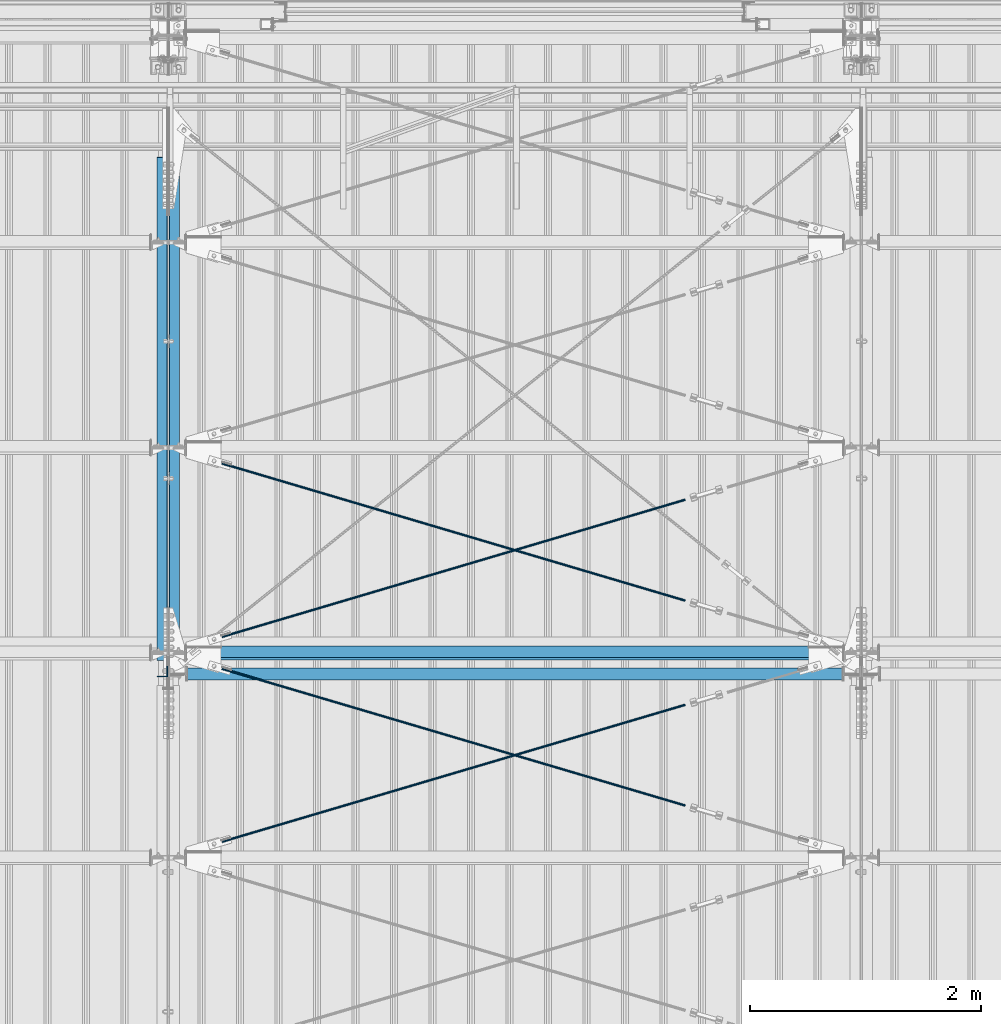
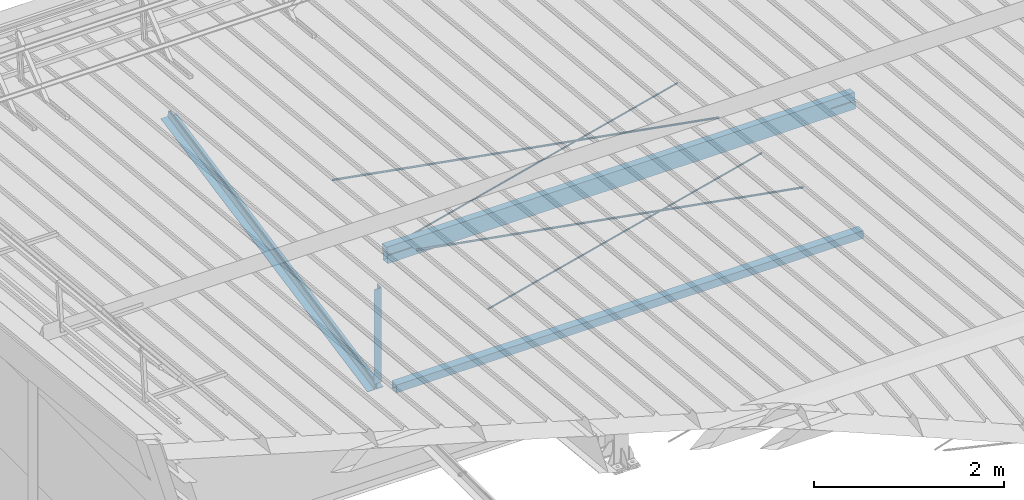
# One storey, part 263 of 709: 9 beams, 6 openings, 9 elements without a shape of their own.
"""IFC4 building model written with IfcOpenShell, lengths in millimetres."""

import ifcopenshell
import ifcopenshell.guid

model = None  # the IFC model being written
_history = None  # IfcOwnerHistory: only IFC2X3 demands one
_inside = {}  # id of a spatial element -> (the spatial element, [elements in it])
_under = {}  # id of a project, library or spatial element -> (it, [spatial elements below it])
_declared = {}  # id of a project -> (the project, [libraries it declares])
_typed = {}  # id of a type object -> (the type object, [elements of that type])
_made_of = {}  # id of a material, layer set ... -> (it, [elements and type objects made of it])


def new_model(schema):
    """Start an empty IFC model of exactly this schema.

    Asked for "IFC4X3", IfcOpenShell would pick the latest addendum, in which some entities
    have other attributes; the version numbers below select the first issue.
    IFC2X3 requires an IfcOwnerHistory on every rooted entity: one is made here for all.
    """
    global model, _history
    if schema == "IFC4X3":
        model = ifcopenshell.file(schema_version=(4, 3, 0, 0))
    else:
        model = ifcopenshell.file(schema=schema)
    _inside.clear()
    _under.clear()
    _declared.clear()
    _typed.clear()
    _made_of.clear()
    _history = None
    if model.schema == "IFC2X3":
        org = make("IfcOrganization", Name="unknown")
        user = make(
            "IfcPersonAndOrganization",
            ThePerson=make("IfcPerson", FamilyName="unknown"),
            TheOrganization=org,
        )
        app = make(
            "IfcApplication",
            ApplicationDeveloper=org,
            Version="unknown",
            ApplicationFullName="unknown",
            ApplicationIdentifier="unknown",
        )
        _history = make(
            "IfcOwnerHistory",
            OwningUser=user,
            OwningApplication=app,
            ChangeAction="ADDED",
            CreationDate=0,
        )
    return model


def make(cls, **values):
    """One entity of the class cls with the attributes given. An attribute that is None is left unset."""
    return model.create_entity(
        cls, **{name: value for name, value in values.items() if value is not None}
    )


def rooted(cls, **values):
    """An entity with a GlobalId (a new one), such as an element, a storey or a relation."""
    return make(cls, GlobalId=ifcopenshell.guid.new(), OwnerHistory=_history, **values)


def si_unit(unit_type, name, prefix=None):
    """IfcSIUnit, for example si_unit("LENGTHUNIT", "METRE", prefix="MILLI")."""
    return make("IfcSIUnit", UnitType=unit_type, Prefix=prefix, Name=name)


def assignment(units):
    """IfcUnitAssignment: the units of a project."""
    return None if units is None else make("IfcUnitAssignment", Units=units)


def point(xyz):
    """IfcCartesianPoint."""
    return None if xyz is None else make("IfcCartesianPoint", Coordinates=xyz)


def direction(xyz):
    """IfcDirection."""
    return None if xyz is None else make("IfcDirection", DirectionRatios=xyz)


def frame(location, z_axis=None, x_axis=None):
    """IfcAxis2Placement3D, a coordinate frame: its origin and axes. An axis left out is left unset."""
    return make(
        "IfcAxis2Placement3D",
        Location=point(location),
        Axis=direction(z_axis),
        RefDirection=direction(x_axis),
    )


def origin_with_axes():
    """The frame at (0, 0, 0) with the z axis (0, 0, 1) and the x axis (1, 0, 0) written out."""
    return frame((0.0, 0.0, 0.0), z_axis=(0.0, 0.0, 1.0), x_axis=(1.0, 0.0, 0.0))


def place(relative_to, where):
    """IfcLocalPlacement: puts the frame where relative to a parent placement (None: the world)."""
    return make(
        "IfcLocalPlacement", PlacementRelTo=relative_to, RelativePlacement=where
    )


def context(
    kind, dimensions, precision=None, world=None, true_north=None, identifier=None
):
    """IfcGeometricRepresentationContext, for example the 3D "Model" context."""
    return make(
        "IfcGeometricRepresentationContext",
        ContextIdentifier=identifier,
        ContextType=kind,
        CoordinateSpaceDimension=dimensions,
        Precision=precision,
        WorldCoordinateSystem=world,
        TrueNorth=true_north,
    )


def subcontext(parent, identifier, kind, view, scale=None):
    """IfcGeometricRepresentationSubContext, for example "Body" below "Model"."""
    return make(
        "IfcGeometricRepresentationSubContext",
        ContextIdentifier=identifier,
        ContextType=kind,
        ParentContext=parent,
        TargetScale=scale,
        TargetView=view,
    )


def project(units=None, contexts=None):
    """IfcProject with its units and contexts."""
    return rooted(
        "IfcProject",
        Name="project",
        RepresentationContexts=contexts,
        UnitsInContext=assignment(units),
    )


def spatial(cls, under=None, at=None, **own):
    """A site, building, storey or space (cls), placed at a placement, below another one or the project."""
    s = rooted(cls, ObjectPlacement=at, **own)
    if under is not None:
        _under.setdefault(under.id(), (under, []))[1].append(s)
    return s


def point_list(points):
    """IfcCartesianPointList2D or 3D."""
    cls = (
        "IfcCartesianPointList2D" if len(points[0]) == 2 else "IfcCartesianPointList3D"
    )
    return make(cls, CoordList=points)


def line(*indices):
    """IfcLineIndex: a straight run through numbered points of an indexed curve."""
    return model.create_entity("IfcLineIndex", indices)


def indexed_curve(points, segments=None, self_intersect=None):
    """IfcIndexedPolyCurve: lines and arcs through numbered points (the first is 1)."""
    return make(
        "IfcIndexedPolyCurve",
        Points=point_list(points),
        Segments=segments,
        SelfIntersect=self_intersect,
    )


def outline(outer, holes=None, kind="AREA"):
    """IfcArbitraryClosedProfileDef: a profile drawn as a closed curve; with holes, ...WithVoids."""
    if holes is None:
        return make("IfcArbitraryClosedProfileDef", ProfileType=kind, OuterCurve=outer)
    return make(
        "IfcArbitraryProfileDefWithVoids",
        ProfileType=kind,
        OuterCurve=outer,
        InnerCurves=holes,
    )


def extrude(swept, where, along, depth):
    """IfcExtrudedAreaSolid: the profile swept, set in the frame where, extruded along a direction by depth."""
    return make(
        "IfcExtrudedAreaSolid",
        SweptArea=swept,
        Position=where,
        ExtrudedDirection=direction(along),
        Depth=depth,
    )


def polygons(points, faces, closed=None, point_numbers=None):
    """IfcPolygonalFaceSet: a face is its outer loop, then its inner loops; points numbered from 1."""
    made = []
    for loops in faces:
        if len(loops) == 1:
            made.append(make("IfcIndexedPolygonalFace", CoordIndex=loops[0]))
        else:
            made.append(
                make(
                    "IfcIndexedPolygonalFaceWithVoids",
                    CoordIndex=loops[0],
                    InnerCoordIndices=loops[1:],
                )
            )
    return make(
        "IfcPolygonalFaceSet",
        Coordinates=point_list(points),
        Closed=closed,
        Faces=made,
        PnIndex=point_numbers,
    )


def shape(context_of_items, identifier, shape_type, items):
    """IfcShapeRepresentation: the items that make up one representation, for example the "Body"."""
    return make(
        "IfcShapeRepresentation",
        ContextOfItems=context_of_items,
        RepresentationIdentifier=identifier,
        RepresentationType=shape_type,
        Items=items,
    )


def material(Name=None, Category=None):
    """IfcMaterial."""
    return make("IfcMaterial", Name=Name, Category=Category)


def made_of(thing, what):
    """Note that an element or type object is made of a material, layer set ...; save() writes the relation."""
    if what is not None:
        _made_of.setdefault(what.id(), (what, []))[1].append(thing)
    return thing


def element(
    cls,
    number,
    at=None,
    inside=None,
    cuts=None,
    type_object=None,
    material=None,
    context=None,
    identifier="Body",
    shape_type=None,
    held_by="IfcProductDefinitionShape",
    body=None,
    shapes=None,
    **own,
):
    """One element of the class cls, such as IfcWall. Its Tag is "e" and its number.

    at: its placement. inside: the storey or other place that contains it. cuts: it is an
    opening in that element (IfcRelVoidsElement). A single representation is given by context,
    identifier, shape_type and body (its items); several are given by shapes. held_by: the class
    of the entity that holds the representations. save() writes the other relations.
    """
    e = rooted(cls, Tag="e%d" % number, ObjectPlacement=at, **own)
    if body is not None:
        shapes = [shape(context, identifier, shape_type, body)]
    if shapes is not None:
        e.Representation = make(held_by, Representations=shapes)
    if inside is not None:
        _inside.setdefault(inside.id(), (inside, []))[1].append(e)
    if cuts is not None:
        rooted(
            "IfcRelVoidsElement", RelatingBuildingElement=cuts, RelatedOpeningElement=e
        )
    if type_object is not None:
        _typed.setdefault(type_object.id(), (type_object, []))[1].append(e)
    return made_of(e, material)


def aggregate(whole, parts):
    """IfcRelAggregates: a whole, such as a stair, and the parts it consists of."""
    return rooted("IfcRelAggregates", RelatingObject=whole, RelatedObjects=parts)


def save(model, path):
    """Write the relations noted so far, then the file.

    IfcRelAggregates (storeys below a building ...), IfcRelContainedInSpatialStructure (elements
    in a storey), IfcRelDefinesByType, IfcRelAssociatesMaterial and IfcRelDeclares: one each for
    every whole, place, type object, material and project.
    """
    for whole, parts in _under.values():
        aggregate(whole, parts)
    for where, things in _inside.values():
        rooted(
            "IfcRelContainedInSpatialStructure",
            RelatedElements=things,
            RelatingStructure=where,
        )
    for kind, things in _typed.values():
        rooted("IfcRelDefinesByType", RelatedObjects=things, RelatingType=kind)
    for what, things in _made_of.values():
        rooted("IfcRelAssociatesMaterial", RelatedObjects=things, RelatingMaterial=what)
    for by, libraries in _declared.values():
        rooted("IfcRelDeclares", RelatingContext=by, RelatedDefinitions=libraries)
    model.write(path)


model = new_model("IFC4")

# Units and contexts
model_context = context("Model", 3, precision=0.2, world=origin_with_axes(), true_north=direction((0.0, 1.0)))
body_context = subcontext(model_context, "Body", "Model", "MODEL_VIEW")
reference_context = subcontext(model_context, "Reference", "Model", "MODEL_VIEW")
ifc_project = project(units=[si_unit("LENGTHUNIT", "METRE", prefix="MILLI"), si_unit("AREAUNIT", "SQUARE_METRE"), si_unit("VOLUMEUNIT", "CUBIC_METRE"), si_unit("MASSUNIT", "GRAM", prefix="KILO"), si_unit("TIMEUNIT", "SECOND"), si_unit("PLANEANGLEUNIT", "RADIAN"), si_unit("SOLIDANGLEUNIT", "STERADIAN"), si_unit("THERMODYNAMICTEMPERATUREUNIT", "DEGREE_CELSIUS"), si_unit("LUMINOUSINTENSITYUNIT", "LUMEN")], contexts=[model_context])

# Site, building, storey
site_placement = place(None, origin_with_axes())
site = spatial("IfcSite", under=ifc_project, at=site_placement, CompositionType="ELEMENT")
building_placement = place(site_placement, origin_with_axes())
building = spatial("IfcBuilding", under=site, at=building_placement, Name="Undefined", CompositionType="ELEMENT")
storey_placement = place(building_placement, origin_with_axes())
storey = spatial("IfcBuildingStorey", under=building, at=storey_placement, Name="Undefined", CompositionType="ELEMENT", Elevation=0.0)

# Assembly, beam
assembly_1_placement = place(storey_placement, frame((4051.0, 21649.9404, 7109.99804), z_axis=(0.0, -0.1961161349, 0.9805806757), x_axis=(0.0, -0.9805806757, -0.1961161349)))
assembly_1 = element("IfcElementAssembly", 1, at=assembly_1_placement, inside=storey)
ifc_material_1 = material(Name="C345-5", Category="STEEL")
beam_1_placement = place(assembly_1_placement, origin_with_axes())
beam_1 = element("IfcBeam", 2, at=beam_1_placement, material=ifc_material_1, ObjectType="435", context=body_context, shape_type="Tessellation", body=[
    polygons([(873.96605, -45.0, -45.0), (873.96605, 45.0, -45.0), (5317.375, 45.0, -45.0), (5317.375, -45.0, -45.0), (873.96605, 45.0, -39.0), (5317.375, 45.0, -39.0), (873.96605, -39.0, -39.0), (5317.375, -39.0, -39.0), (873.96605, -39.0, 45.0), (5317.375, -39.0, 45.0), (873.96605, -45.0, 45.0), (5317.375, -45.0, 45.0)], [[[1, 2, 3, 4]], [[2, 5, 6, 3]], [[5, 7, 8, 6]], [[7, 9, 10, 8]], [[9, 11, 12, 10]], [[11, 1, 4, 12]], [[6, 8, 10, 12, 4, 3]], [[11, 9, 7, 5, 2, 1]]], closed=True),
])
aggregate(assembly_1, [beam_1])

assembly_2_placement = place(storey_placement, frame((3949.0, 16322.9404, 6044.59804), z_axis=(0.0, -0.1961161349, 0.9805806757), x_axis=(0.0, 0.9805806757, 0.1961161349)))
assembly_2 = element("IfcElementAssembly", 3, at=assembly_2_placement, inside=storey)
beam_2_placement = place(assembly_2_placement, origin_with_axes())
beam_2 = element("IfcBeam", 4, at=beam_2_placement, material=ifc_material_1, ObjectType="435", context=body_context, shape_type="Tessellation", body=[
    polygons([(115.12039, -45.0, -45.0), (115.12039, 45.0, -45.0), (4558.52934, 45.0, -45.0), (4558.52934, -45.0, -45.0), (115.12039, 45.0, -39.0), (4558.52934, 45.0, -39.0), (115.12039, -39.0, -39.0), (4558.52934, -39.0, -39.0), (115.12039, -39.0, 45.0), (4558.52934, -39.0, 45.0), (115.12039, -45.0, 45.0), (4558.52934, -45.0, 45.0)], [[[1, 2, 3, 4]], [[2, 5, 6, 3]], [[5, 7, 8, 6]], [[7, 9, 10, 8]], [[9, 11, 12, 10]], [[11, 1, 4, 12]], [[6, 8, 10, 12, 4, 3]], [[11, 9, 7, 5, 2, 1]]], closed=True),
])
aggregate(assembly_2, [beam_2])

assembly_3_placement = place(storey_placement, frame((3949.0, 16347.7, 7622.40002), z_axis=(0.0, 1.0, 0.0), x_axis=(0.0, 0.0, -1.0)))
assembly_3 = element("IfcElementAssembly", 5, at=assembly_3_placement, inside=storey)
beam_3_placement = place(assembly_3_placement, origin_with_axes())
beam_3 = element("IfcBeam", 6, at=beam_3_placement, material=ifc_material_1, ObjectType="436", context=body_context, shape_type="Tessellation", body=[
    polygons([(198.6891, -45.0, -45.0), (198.6891, 45.0, -45.0), (1412.4, 45.0, -45.0), (1412.4, -45.0, -45.0), (198.6891, 45.0, -39.0), (1412.4, 45.0, -39.0), (198.6891, -39.0, -39.0), (1412.4, -39.0, -39.0), (198.6891, -39.0, 45.0), (1412.4, -39.0, 45.0), (198.6891, -45.0, 45.0), (1412.4, -45.0, 45.0)], [[[1, 2, 3, 4]], [[2, 5, 6, 3]], [[5, 7, 8, 6]], [[7, 9, 10, 8]], [[9, 11, 12, 10]], [[11, 1, 4, 12]], [[6, 8, 10, 12, 4, 3]], [[11, 9, 7, 5, 2, 1]]], closed=True),
])
aggregate(assembly_3, [beam_3])

assembly_4_placement = place(storey_placement, frame((4000.0, 16327.0, 6074.30002), z_axis=(0.0, -1.0, 0.0), x_axis=(1.0, 0.0, 0.0)))
assembly_4 = element("IfcElementAssembly", 7, at=assembly_4_placement, inside=storey)
ifc_material_2 = material(Name="C355", Category="STEEL")
beam_4_placement = place(assembly_4_placement, origin_with_axes())
beam_4 = element("IfcBeam", 8, at=beam_4_placement, material=ifc_material_2, ObjectType="557", context=body_context, shape_type="Tessellation", body=[
    polygons([(162.0, -47.0, -47.0), (162.0, -47.0, 47.0), (5838.0, -47.0, 47.0), (5838.0, -47.0, -47.0), (162.0, 47.0, 47.0), (5838.0, 47.0, 47.0), (162.0, 47.0, -47.0), (5838.0, 47.0, -47.0), (162.0, -50.0, -50.0), (162.0, 50.0, -50.0), (5838.0, 50.0, -50.0), (5838.0, -50.0, -50.0), (162.0, 50.0, 50.0), (5838.0, 50.0, 50.0), (162.0, -50.0, 50.0), (5838.0, -50.0, 50.0)], [[[1, 2, 3, 4]], [[2, 5, 6, 3]], [[5, 7, 8, 6]], [[7, 1, 4, 8]], [[9, 10, 11, 12]], [[10, 13, 14, 11]], [[13, 15, 16, 14]], [[15, 9, 12, 16]], [[14, 16, 12, 11], [6, 8, 4, 3]], [[15, 13, 10, 9], [7, 5, 2, 1]]], closed=True),
])
aggregate(assembly_4, [beam_4])

# Assembly, beam, voiding feature
assembly_5_placement = place(storey_placement, frame((4000.0, 14737.44615, 7862.7594), z_axis=(0.2847296511, -0.9538504697, 0.095385047), x_axis=(0.9586078582, 0.2833165921, -0.028331659)))
assembly_5 = element("IfcElementAssembly", 9, at=assembly_5_placement, inside=storey)
ifc_material_3 = material(Name="C355-5", Category="STEEL")
beam_5_placement = place(assembly_5_placement, origin_with_axes())
beam_5 = element("IfcBeam", 10, at=beam_5_placement, material=ifc_material_3, ObjectType="572", context=body_context, shape_type="Tessellation", body=[
    polygons([(4849.07659, 7.36122, 4.25), (4849.07659, 6.01041, 6.01041), (4849.07659, 4.25, 7.36122), (4849.07659, 2.19996, 8.21037), (4849.07659, 0.0, 8.5), (4849.07659, -2.19996, 8.21037), (4849.07659, -4.25, 7.36122), (4849.07659, -6.01041, 6.01041), (4849.07659, -7.36121, 4.25), (4849.07659, -8.21037, 2.19996), (4849.07659, -8.5, 0.0), (4849.07659, -8.21037, -2.19996), (4849.07659, -7.36121, -4.25), (4849.07659, -6.01041, -6.01041), (4849.07659, -4.25, -7.36122), (4849.07659, -2.19996, -8.21037), (4849.07659, 0.0, -8.5), (4849.07659, 2.19996, -8.21037), (4849.07659, 4.25, -7.36122), (4849.07659, 6.01041, -6.01041), (4849.07659, 7.36122, -4.25), (4849.07659, 8.21037, -2.19996), (4849.07659, 8.5, 0.0), (4849.07659, 8.21037, 2.19996), (4669.07659, 8.21037, 2.19996), (4669.07659, 7.36122, 4.25), (4669.07659, 6.01041, 6.01041), (4669.07659, 4.25, 7.36122), (4669.07659, 2.19996, 8.21037), (4669.07659, 0.0, 8.5), (4669.07659, -2.19996, 8.21037), (4669.07659, -4.25, 7.36122), (4669.07659, -6.01041, 6.01041), (4669.07659, -7.36121, 4.25), (4669.07659, -8.21037, 2.19996), (4669.07659, -8.5, 0.0), (4669.07659, -8.21037, -2.19996), (4669.07659, -7.36121, -4.25), (4669.07659, -6.01041, -6.01041), (4669.07659, -4.25, -7.36122), (4669.07659, -2.19996, -8.21037), (4669.07659, 0.0, -8.5), (4669.07659, 2.19996, -8.21037), (4669.07659, 4.25, -7.36122), (4669.07659, 6.01041, -6.01041), (4669.07659, 7.36122, -4.25), (4669.07659, 8.21037, -2.19996), (4669.07659, 8.5, 0.0), (4669.07659, 10.0, 0.0), (4669.07659, 9.65926, 2.58819), (4669.07659, 8.66025, 5.0), (4669.07659, 7.07107, 7.07107), (4669.07659, 5.0, 8.66025), (4669.07659, 2.58819, 9.65926), (4669.07659, 0.0, 10.0), (4669.07659, -2.58819, 9.65926), (4669.07659, -5.0, 8.66025), (4669.07659, -7.07107, 7.07107), (4669.07659, -8.66025, 5.0), (4669.07659, -9.65926, 2.58819), (4669.07659, -10.0, 0.0), (4669.07659, -9.65926, -2.58819), (4669.07659, -8.66025, -5.0), (4669.07659, -7.07107, -7.07107), (4669.07659, -5.0, -8.66025), (4669.07659, -2.58819, -9.65926), (4669.07659, 0.0, -10.0), (4669.07659, 2.58819, -9.65926), (4669.07659, 5.0, -8.66025), (4669.07659, 7.07107, -7.07107), (4669.07659, 8.66025, -5.0), (4669.07659, 9.65926, -2.58819), (483.68279, 2.58819, 9.65926), (483.68279, 5.0, 8.66025), (483.68279, 7.07107, 7.07107), (483.68279, 8.66025, 5.0), (483.68279, 9.65926, 2.58819), (483.68279, 10.0, 0.0), (483.68279, 9.65926, -2.58819), (483.68279, 8.66025, -5.0), (483.68279, 7.07107, -7.07107), (483.68279, 5.0, -8.66025), (483.68279, 2.58819, -9.65926), (483.68279, 0.0, -10.0), (483.68279, -2.58819, -9.65926), (483.68279, -5.0, -8.66025), (483.68279, -7.07107, -7.07107), (483.68279, -8.66025, -5.0), (483.68279, -9.65926, -2.58819), (483.68279, -10.0, 0.0), (483.68279, -9.65926, 2.58819), (483.68279, -8.66025, 5.0), (483.68279, -7.07107, 7.07107), (483.68279, -5.0, 8.66025), (483.68279, -2.58819, 9.65926), (483.68279, 0.0, 10.0)], [[[1, 2, 3, 4, 5, 6, 7, 8, 9, 10, 11, 12, 13, 14, 15, 16, 17, 18, 19, 20, 21, 22, 23, 24]], [[24, 25, 26, 1]], [[1, 26, 27, 2]], [[2, 27, 28, 3]], [[3, 28, 29, 4]], [[4, 29, 30, 5]], [[5, 30, 31, 6]], [[6, 31, 32, 7]], [[7, 32, 33, 8]], [[8, 33, 34, 9]], [[9, 34, 35, 10]], [[10, 35, 36, 11]], [[11, 36, 37, 12]], [[12, 37, 38, 13]], [[13, 38, 39, 14]], [[14, 39, 40, 15]], [[15, 40, 41, 16]], [[16, 41, 42, 17]], [[17, 42, 43, 18]], [[18, 43, 44, 19]], [[19, 44, 45, 20]], [[20, 45, 46, 21]], [[21, 46, 47, 22]], [[22, 47, 48, 23]], [[23, 48, 25, 24]], [[49, 50, 51, 52, 53, 54, 55, 56, 57, 58, 59, 60, 61, 62, 63, 64, 65, 66, 67, 68, 69, 70, 71, 72], [47, 46, 45, 44, 43, 42, 41, 40, 39, 38, 37, 36, 35, 34, 33, 32, 31, 30, 29, 28, 27, 26, 25, 48]], [[73, 74, 75, 76, 77, 78, 79, 80, 81, 82, 83, 84, 85, 86, 87, 88, 89, 90, 91, 92, 93, 94, 95, 96]], [[79, 78, 49, 72]], [[80, 79, 72, 71]], [[81, 80, 71, 70]], [[82, 81, 70, 69]], [[83, 82, 69, 68]], [[84, 83, 68, 67]], [[85, 84, 67, 66]], [[86, 85, 66, 65]], [[87, 86, 65, 64]], [[88, 87, 64, 63]], [[89, 88, 63, 62]], [[90, 89, 62, 61]], [[91, 90, 61, 60]], [[92, 91, 60, 59]], [[93, 92, 59, 58]], [[94, 93, 58, 57]], [[95, 94, 57, 56]], [[96, 95, 56, 55]], [[73, 96, 55, 54]], [[74, 73, 54, 53]], [[75, 74, 53, 52]], [[76, 75, 52, 51]], [[77, 76, 51, 50]], [[78, 77, 50, 49]]], closed=True),
])
voiding_feature_1_placement = place(beam_5_placement, frame((4849.07659, 0.0, 0.0), z_axis=(0.0, 1.0, 0.0), x_axis=(-1.0, 0.0, 0.0)))
element("IfcVoidingFeature", 11, at=voiding_feature_1_placement, cuts=beam_5, PredefinedType="HOLE", context=reference_context, identifier="Reference", shape_type="SolidModel", body=[
    extrude(outline(indexed_curve([(10.5, 0.0), (10.14222, 2.7176), (9.09327, 5.25), (7.42462, 7.42462), (5.25, 9.09327), (2.7176, 10.14222), (0.0, 10.5), (-2.7176, 10.14222), (-5.25, 9.09327), (-7.42462, 7.42462), (-9.09327, 5.25), (-10.14222, 2.7176), (-10.5, 0.0), (-10.14222, -2.7176), (-9.09327, -5.25), (-7.42462, -7.42462), (-5.25, -9.09327), (-2.7176, -10.14222), (0.0, -10.5), (2.7176, -10.14222), (5.25, -9.09327), (7.42462, -7.42462), (9.09327, -5.25), (10.14222, -2.7176)], segments=[line(1, 2, 3, 4, 5, 6, 7, 8, 9, 10, 11, 12, 13, 14, 15, 16, 17, 18, 19, 20, 21, 22, 23, 24, 1)])), frame((0.0, 0.0, 0.0), z_axis=(-1.0, 0.0, 0.0), x_axis=(0.0, 0.0, 1.0)), (0.0, 0.0, -1.0), 180.0),
])
aggregate(assembly_5, [beam_5])

assembly_6_placement = place(storey_placement, frame((4000.0, 16510.7464, 7685.42938), z_axis=(-0.2847296511, -0.9538504697, 0.095385047), x_axis=(0.9586078582, -0.2833165921, 0.028331659)))
assembly_6 = element("IfcElementAssembly", 12, at=assembly_6_placement, inside=storey)
beam_6_placement = place(assembly_6_placement, origin_with_axes())
beam_6 = element("IfcBeam", 13, at=beam_6_placement, material=ifc_material_3, ObjectType="572", context=body_context, shape_type="Tessellation", body=[
    polygons([(4849.07659, 7.36122, 4.25), (4849.07659, 6.01041, 6.01041), (4849.07659, 4.25, 7.36122), (4849.07659, 2.19996, 8.21037), (4849.07659, 0.0, 8.5), (4849.07659, -2.19996, 8.21037), (4849.07659, -4.25, 7.36122), (4849.07659, -6.01041, 6.01041), (4849.07659, -7.36121, 4.25), (4849.07659, -8.21037, 2.19996), (4849.07659, -8.5, 0.0), (4849.07659, -8.21037, -2.19996), (4849.07659, -7.36121, -4.25), (4849.07659, -6.01041, -6.01041), (4849.07659, -4.25, -7.36122), (4849.07659, -2.19996, -8.21037), (4849.07659, 0.0, -8.5), (4849.07659, 2.19996, -8.21037), (4849.07659, 4.25, -7.36122), (4849.07659, 6.01041, -6.01041), (4849.07659, 7.36122, -4.25), (4849.07659, 8.21037, -2.19996), (4849.07659, 8.5, 0.0), (4849.07659, 8.21037, 2.19996), (4669.07659, 8.21037, 2.19996), (4669.07659, 7.36122, 4.25), (4669.07659, 6.01041, 6.01041), (4669.07659, 4.25, 7.36122), (4669.07659, 2.19996, 8.21037), (4669.07659, 0.0, 8.5), (4669.07659, -2.19996, 8.21037), (4669.07659, -4.25, 7.36122), (4669.07659, -6.01041, 6.01041), (4669.07659, -7.36121, 4.25), (4669.07659, -8.21037, 2.19996), (4669.07659, -8.5, 0.0), (4669.07659, -8.21037, -2.19996), (4669.07659, -7.36121, -4.25), (4669.07659, -6.01041, -6.01041), (4669.07659, -4.25, -7.36122), (4669.07659, -2.19996, -8.21037), (4669.07659, 0.0, -8.5), (4669.07659, 2.19996, -8.21037), (4669.07659, 4.25, -7.36122), (4669.07659, 6.01041, -6.01041), (4669.07659, 7.36122, -4.25), (4669.07659, 8.21037, -2.19996), (4669.07659, 8.5, 0.0), (4669.07659, 10.0, 0.0), (4669.07659, 9.65926, 2.58819), (4669.07659, 8.66025, 5.0), (4669.07659, 7.07107, 7.07107), (4669.07659, 5.0, 8.66025), (4669.07659, 2.58819, 9.65926), (4669.07659, 0.0, 10.0), (4669.07659, -2.58819, 9.65926), (4669.07659, -5.0, 8.66025), (4669.07659, -7.07107, 7.07107), (4669.07659, -8.66025, 5.0), (4669.07659, -9.65926, 2.58819), (4669.07659, -10.0, 0.0), (4669.07659, -9.65926, -2.58819), (4669.07659, -8.66025, -5.0), (4669.07659, -7.07107, -7.07107), (4669.07659, -5.0, -8.66025), (4669.07659, -2.58819, -9.65926), (4669.07659, 0.0, -10.0), (4669.07659, 2.58819, -9.65926), (4669.07659, 5.0, -8.66025), (4669.07659, 7.07107, -7.07107), (4669.07659, 8.66025, -5.0), (4669.07659, 9.65926, -2.58819), (483.68279, 2.58819, 9.65926), (483.68279, 5.0, 8.66025), (483.68279, 7.07107, 7.07107), (483.68279, 8.66025, 5.0), (483.68279, 9.65926, 2.58819), (483.68279, 10.0, 0.0), (483.68279, 9.65926, -2.58819), (483.68279, 8.66025, -5.0), (483.68279, 7.07107, -7.07107), (483.68279, 5.0, -8.66025), (483.68279, 2.58819, -9.65926), (483.68279, 0.0, -10.0), (483.68279, -2.58819, -9.65926), (483.68279, -5.0, -8.66025), (483.68279, -7.07107, -7.07107), (483.68279, -8.66025, -5.0), (483.68279, -9.65926, -2.58819), (483.68279, -10.0, 0.0), (483.68279, -9.65926, 2.58819), (483.68279, -8.66025, 5.0), (483.68279, -7.07107, 7.07107), (483.68279, -5.0, 8.66025), (483.68279, -2.58819, 9.65926), (483.68279, 0.0, 10.0)], [[[1, 2, 3, 4, 5, 6, 7, 8, 9, 10, 11, 12, 13, 14, 15, 16, 17, 18, 19, 20, 21, 22, 23, 24]], [[24, 25, 26, 1]], [[1, 26, 27, 2]], [[2, 27, 28, 3]], [[3, 28, 29, 4]], [[4, 29, 30, 5]], [[5, 30, 31, 6]], [[6, 31, 32, 7]], [[7, 32, 33, 8]], [[8, 33, 34, 9]], [[9, 34, 35, 10]], [[10, 35, 36, 11]], [[11, 36, 37, 12]], [[12, 37, 38, 13]], [[13, 38, 39, 14]], [[14, 39, 40, 15]], [[15, 40, 41, 16]], [[16, 41, 42, 17]], [[17, 42, 43, 18]], [[18, 43, 44, 19]], [[19, 44, 45, 20]], [[20, 45, 46, 21]], [[21, 46, 47, 22]], [[22, 47, 48, 23]], [[23, 48, 25, 24]], [[49, 50, 51, 52, 53, 54, 55, 56, 57, 58, 59, 60, 61, 62, 63, 64, 65, 66, 67, 68, 69, 70, 71, 72], [47, 46, 45, 44, 43, 42, 41, 40, 39, 38, 37, 36, 35, 34, 33, 32, 31, 30, 29, 28, 27, 26, 25, 48]], [[73, 74, 75, 76, 77, 78, 79, 80, 81, 82, 83, 84, 85, 86, 87, 88, 89, 90, 91, 92, 93, 94, 95, 96]], [[79, 78, 49, 72]], [[80, 79, 72, 71]], [[81, 80, 71, 70]], [[82, 81, 70, 69]], [[83, 82, 69, 68]], [[84, 83, 68, 67]], [[85, 84, 67, 66]], [[86, 85, 66, 65]], [[87, 86, 65, 64]], [[88, 87, 64, 63]], [[89, 88, 63, 62]], [[90, 89, 62, 61]], [[91, 90, 61, 60]], [[92, 91, 60, 59]], [[93, 92, 59, 58]], [[94, 93, 58, 57]], [[95, 94, 57, 56]], [[96, 95, 56, 55]], [[73, 96, 55, 54]], [[74, 73, 54, 53]], [[75, 74, 53, 52]], [[76, 75, 52, 51]], [[77, 76, 51, 50]], [[78, 77, 50, 49]]], closed=True),
])
voiding_feature_2_placement = place(beam_6_placement, frame((4849.07659, 0.0, 0.0), z_axis=(0.0, 1.0, 0.0), x_axis=(-1.0, 0.0, 0.0)))
element("IfcVoidingFeature", 14, at=voiding_feature_2_placement, cuts=beam_6, PredefinedType="HOLE", context=reference_context, identifier="Reference", shape_type="SolidModel", body=[
    extrude(outline(indexed_curve([(10.5, 0.0), (10.14222, 2.7176), (9.09327, 5.25), (7.42462, 7.42462), (5.25, 9.09327), (2.7176, 10.14222), (0.0, 10.5), (-2.7176, 10.14222), (-5.25, 9.09327), (-7.42462, 7.42462), (-9.09327, 5.25), (-10.14222, 2.7176), (-10.5, 0.0), (-10.14222, -2.7176), (-9.09327, -5.25), (-7.42462, -7.42462), (-5.25, -9.09327), (-2.7176, -10.14222), (0.0, -10.5), (2.7176, -10.14222), (5.25, -9.09327), (7.42462, -7.42462), (9.09327, -5.25), (10.14222, -2.7176)], segments=[line(1, 2, 3, 4, 5, 6, 7, 8, 9, 10, 11, 12, 13, 14, 15, 16, 17, 18, 19, 20, 21, 22, 23, 24, 1)])), frame((0.0, 0.0, 0.0), z_axis=(-1.0, 0.0, 0.0), x_axis=(0.0, 0.0, 1.0)), (0.0, 0.0, -1.0), 180.0),
])
aggregate(assembly_6, [beam_6])

assembly_7_placement = place(storey_placement, frame((4000.0, 16510.7464, 7685.42938), z_axis=(0.2852311229, -0.9537021177, 0.0953702118), x_axis=(0.9584587662, 0.2838155751, -0.028381558)))
assembly_7 = element("IfcElementAssembly", 15, at=assembly_7_placement, inside=storey)
beam_7_placement = place(assembly_7_placement, origin_with_axes())
beam_7 = element("IfcBeam", 16, at=beam_7_placement, material=ifc_material_3, ObjectType="570", context=body_context, shape_type="Tessellation", body=[
    polygons([(4850.05021, 7.36122, 4.25), (4850.05021, 6.01041, 6.01041), (4850.05021, 4.25, 7.36121), (4850.05021, 2.19996, 8.21037), (4850.05021, 0.0, 8.5), (4850.05021, -2.19996, 8.21037), (4850.05021, -4.25, 7.36121), (4850.05021, -6.01041, 6.01041), (4850.05021, -7.36121, 4.25), (4850.05021, -8.21037, 2.19996), (4850.05021, -8.5, 0.0), (4850.05021, -8.21037, -2.19996), (4850.05021, -7.36121, -4.25), (4850.05021, -6.01041, -6.01041), (4850.05021, -4.25, -7.36122), (4850.05021, -2.19996, -8.21037), (4850.05021, 0.0, -8.5), (4850.05021, 2.19996, -8.21037), (4850.05021, 4.25, -7.36122), (4850.05021, 6.01041, -6.01041), (4850.05021, 7.36122, -4.25), (4850.05021, 8.21037, -2.19996), (4850.05021, 8.5, 0.0), (4850.05021, 8.21037, 2.19996), (4670.05021, 8.21037, 2.19996), (4670.05021, 7.36122, 4.25), (4670.05021, 6.01041, 6.01041), (4670.05021, 4.25, 7.36121), (4670.05021, 2.19996, 8.21037), (4670.05021, 0.0, 8.5), (4670.05021, -2.19996, 8.21037), (4670.05021, -4.25, 7.36121), (4670.05021, -6.01041, 6.01041), (4670.05021, -7.36121, 4.25), (4670.05021, -8.21037, 2.19996), (4670.05021, -8.5, 0.0), (4670.05021, -8.21037, -2.19996), (4670.05021, -7.36121, -4.25), (4670.05021, -6.01041, -6.01041), (4670.05021, -4.25, -7.36122), (4670.05021, -2.19996, -8.21037), (4670.05021, 0.0, -8.5), (4670.05021, 2.19996, -8.21037), (4670.05021, 4.25, -7.36122), (4670.05021, 6.01041, -6.01041), (4670.05021, 7.36122, -4.25), (4670.05021, 8.21037, -2.19996), (4670.05021, 8.5, 0.0), (4670.05021, 10.0, 0.0), (4670.05021, 9.65926, 2.58819), (4670.05021, 8.66025, 5.0), (4670.05021, 7.07107, 7.07107), (4670.05021, 5.0, 8.66025), (4670.05021, 2.58819, 9.65926), (4670.05021, 0.0, 10.0), (4670.05021, -2.58819, 9.65926), (4670.05021, -5.0, 8.66025), (4670.05021, -7.07107, 7.07107), (4670.05021, -8.66025, 5.0), (4670.05021, -9.65926, 2.58819), (4670.05021, -10.0, 0.0), (4670.05021, -9.65926, -2.58819), (4670.05021, -8.66025, -5.0), (4670.05021, -7.07107, -7.07107), (4670.05021, -5.0, -8.66025), (4670.05021, -2.58819, -9.65926), (4670.05021, 0.0, -10.0), (4670.05021, 2.58819, -9.65926), (4670.05021, 5.0, -8.66025), (4670.05021, 7.07107, -7.07107), (4670.05021, 8.66025, -5.0), (4670.05021, 9.65926, -2.58819), (483.0251, 2.58819, 9.65926), (483.0251, 5.0, 8.66025), (483.0251, 7.07107, 7.07107), (483.0251, 8.66025, 5.0), (483.0251, 9.65926, 2.58819), (483.0251, 10.0, 0.0), (483.0251, 9.65926, -2.58819), (483.0251, 8.66025, -5.0), (483.0251, 7.07107, -7.07107), (483.0251, 5.0, -8.66025), (483.0251, 2.58819, -9.65926), (483.0251, 0.0, -10.0), (483.0251, -2.58819, -9.65926), (483.0251, -5.0, -8.66025), (483.0251, -7.07107, -7.07107), (483.0251, -8.66025, -5.0), (483.0251, -9.65926, -2.58819), (483.0251, -10.0, 0.0), (483.0251, -9.65926, 2.58819), (483.0251, -8.66025, 5.0), (483.0251, -7.07107, 7.07107), (483.0251, -5.0, 8.66025), (483.0251, -2.58819, 9.65926), (483.0251, 0.0, 10.0)], [[[1, 2, 3, 4, 5, 6, 7, 8, 9, 10, 11, 12, 13, 14, 15, 16, 17, 18, 19, 20, 21, 22, 23, 24]], [[24, 25, 26, 1]], [[1, 26, 27, 2]], [[2, 27, 28, 3]], [[3, 28, 29, 4]], [[4, 29, 30, 5]], [[5, 30, 31, 6]], [[6, 31, 32, 7]], [[7, 32, 33, 8]], [[8, 33, 34, 9]], [[9, 34, 35, 10]], [[10, 35, 36, 11]], [[11, 36, 37, 12]], [[12, 37, 38, 13]], [[13, 38, 39, 14]], [[14, 39, 40, 15]], [[15, 40, 41, 16]], [[16, 41, 42, 17]], [[17, 42, 43, 18]], [[18, 43, 44, 19]], [[19, 44, 45, 20]], [[20, 45, 46, 21]], [[21, 46, 47, 22]], [[22, 47, 48, 23]], [[23, 48, 25, 24]], [[49, 50, 51, 52, 53, 54, 55, 56, 57, 58, 59, 60, 61, 62, 63, 64, 65, 66, 67, 68, 69, 70, 71, 72], [47, 46, 45, 44, 43, 42, 41, 40, 39, 38, 37, 36, 35, 34, 33, 32, 31, 30, 29, 28, 27, 26, 25, 48]], [[73, 74, 75, 76, 77, 78, 79, 80, 81, 82, 83, 84, 85, 86, 87, 88, 89, 90, 91, 92, 93, 94, 95, 96]], [[79, 78, 49, 72]], [[80, 79, 72, 71]], [[81, 80, 71, 70]], [[82, 81, 70, 69]], [[83, 82, 69, 68]], [[84, 83, 68, 67]], [[85, 84, 67, 66]], [[86, 85, 66, 65]], [[87, 86, 65, 64]], [[88, 87, 64, 63]], [[89, 88, 63, 62]], [[90, 89, 62, 61]], [[91, 90, 61, 60]], [[92, 91, 60, 59]], [[93, 92, 59, 58]], [[94, 93, 58, 57]], [[95, 94, 57, 56]], [[96, 95, 56, 55]], [[73, 96, 55, 54]], [[74, 73, 54, 53]], [[75, 74, 53, 52]], [[76, 75, 52, 51]], [[77, 76, 51, 50]], [[78, 77, 50, 49]]], closed=True),
])
voiding_feature_3_placement = place(beam_7_placement, frame((4850.05021, 0.0, 0.0), z_axis=(0.0, 1.0, 0.0), x_axis=(-1.0, 0.0, 0.0)))
element("IfcVoidingFeature", 17, at=voiding_feature_3_placement, cuts=beam_7, PredefinedType="HOLE", context=reference_context, identifier="Reference", shape_type="SolidModel", body=[
    extrude(outline(indexed_curve([(10.5, 0.0), (10.14222, 2.7176), (9.09327, 5.25), (7.42462, 7.42462), (5.25, 9.09327), (2.7176, 10.14222), (0.0, 10.5), (-2.7176, 10.14222), (-5.25, 9.09327), (-7.42462, 7.42462), (-9.09327, 5.25), (-10.14222, 2.7176), (-10.5, 0.0), (-10.14222, -2.7176), (-9.09327, -5.25), (-7.42462, -7.42462), (-5.25, -9.09327), (-2.7176, -10.14222), (0.0, -10.5), (2.7176, -10.14222), (5.25, -9.09327), (7.42462, -7.42462), (9.09327, -5.25), (10.14222, -2.7176)], segments=[line(1, 2, 3, 4, 5, 6, 7, 8, 9, 10, 11, 12, 13, 14, 15, 16, 17, 18, 19, 20, 21, 22, 23, 24, 1)])), frame((0.0, 0.0, 0.0), z_axis=(-1.0, 0.0, 0.0), x_axis=(0.0, 0.0, 1.0)), (0.0, 0.0, -1.0), 180.0),
])
aggregate(assembly_7, [beam_7])

assembly_8_placement = place(storey_placement, frame((4000.0, 18287.44615, 7507.7594), z_axis=(-0.2852311229, -0.9537021177, 0.0953702118), x_axis=(0.9584587662, -0.2838155751, 0.028381558)))
assembly_8 = element("IfcElementAssembly", 18, at=assembly_8_placement, inside=storey)
beam_8_placement = place(assembly_8_placement, origin_with_axes())
beam_8 = element("IfcBeam", 19, at=beam_8_placement, material=ifc_material_3, ObjectType="570", context=body_context, shape_type="Tessellation", body=[
    polygons([(4850.05021, 7.36122, 4.25), (4850.05021, 6.01041, 6.01041), (4850.05021, 4.25, 7.36121), (4850.05021, 2.19996, 8.21037), (4850.05021, 0.0, 8.5), (4850.05021, -2.19996, 8.21037), (4850.05021, -4.25, 7.36121), (4850.05021, -6.01041, 6.01041), (4850.05021, -7.36121, 4.25), (4850.05021, -8.21037, 2.19996), (4850.05021, -8.5, 0.0), (4850.05021, -8.21037, -2.19996), (4850.05021, -7.36121, -4.25), (4850.05021, -6.01041, -6.01041), (4850.05021, -4.25, -7.36122), (4850.05021, -2.19996, -8.21037), (4850.05021, 0.0, -8.5), (4850.05021, 2.19996, -8.21037), (4850.05021, 4.25, -7.36122), (4850.05021, 6.01041, -6.01041), (4850.05021, 7.36122, -4.25), (4850.05021, 8.21037, -2.19996), (4850.05021, 8.5, 0.0), (4850.05021, 8.21037, 2.19996), (4670.05021, 8.21037, 2.19996), (4670.05021, 7.36122, 4.25), (4670.05021, 6.01041, 6.01041), (4670.05021, 4.25, 7.36121), (4670.05021, 2.19996, 8.21037), (4670.05021, 0.0, 8.5), (4670.05021, -2.19996, 8.21037), (4670.05021, -4.25, 7.36121), (4670.05021, -6.01041, 6.01041), (4670.05021, -7.36121, 4.25), (4670.05021, -8.21037, 2.19996), (4670.05021, -8.5, 0.0), (4670.05021, -8.21037, -2.19996), (4670.05021, -7.36121, -4.25), (4670.05021, -6.01041, -6.01041), (4670.05021, -4.25, -7.36122), (4670.05021, -2.19996, -8.21037), (4670.05021, 0.0, -8.5), (4670.05021, 2.19996, -8.21037), (4670.05021, 4.25, -7.36122), (4670.05021, 6.01041, -6.01041), (4670.05021, 7.36122, -4.25), (4670.05021, 8.21037, -2.19996), (4670.05021, 8.5, 0.0), (4670.05021, 10.0, 0.0), (4670.05021, 9.65926, 2.58819), (4670.05021, 8.66025, 5.0), (4670.05021, 7.07107, 7.07107), (4670.05021, 5.0, 8.66025), (4670.05021, 2.58819, 9.65926), (4670.05021, 0.0, 10.0), (4670.05021, -2.58819, 9.65926), (4670.05021, -5.0, 8.66025), (4670.05021, -7.07107, 7.07107), (4670.05021, -8.66025, 5.0), (4670.05021, -9.65926, 2.58819), (4670.05021, -10.0, 0.0), (4670.05021, -9.65926, -2.58819), (4670.05021, -8.66025, -5.0), (4670.05021, -7.07107, -7.07107), (4670.05021, -5.0, -8.66025), (4670.05021, -2.58819, -9.65926), (4670.05021, 0.0, -10.0), (4670.05021, 2.58819, -9.65926), (4670.05021, 5.0, -8.66025), (4670.05021, 7.07107, -7.07107), (4670.05021, 8.66025, -5.0), (4670.05021, 9.65926, -2.58819), (483.0251, 2.58819, 9.65926), (483.0251, 5.0, 8.66025), (483.0251, 7.07107, 7.07107), (483.0251, 8.66025, 5.0), (483.0251, 9.65926, 2.58819), (483.0251, 10.0, 0.0), (483.0251, 9.65926, -2.58819), (483.0251, 8.66025, -5.0), (483.0251, 7.07107, -7.07107), (483.0251, 5.0, -8.66025), (483.0251, 2.58819, -9.65926), (483.0251, 0.0, -10.0), (483.0251, -2.58819, -9.65926), (483.0251, -5.0, -8.66025), (483.0251, -7.07107, -7.07107), (483.0251, -8.66025, -5.0), (483.0251, -9.65926, -2.58819), (483.0251, -10.0, 0.0), (483.0251, -9.65926, 2.58819), (483.0251, -8.66025, 5.0), (483.0251, -7.07107, 7.07107), (483.0251, -5.0, 8.66025), (483.0251, -2.58819, 9.65926), (483.0251, 0.0, 10.0)], [[[1, 2, 3, 4, 5, 6, 7, 8, 9, 10, 11, 12, 13, 14, 15, 16, 17, 18, 19, 20, 21, 22, 23, 24]], [[24, 25, 26, 1]], [[1, 26, 27, 2]], [[2, 27, 28, 3]], [[3, 28, 29, 4]], [[4, 29, 30, 5]], [[5, 30, 31, 6]], [[6, 31, 32, 7]], [[7, 32, 33, 8]], [[8, 33, 34, 9]], [[9, 34, 35, 10]], [[10, 35, 36, 11]], [[11, 36, 37, 12]], [[12, 37, 38, 13]], [[13, 38, 39, 14]], [[14, 39, 40, 15]], [[15, 40, 41, 16]], [[16, 41, 42, 17]], [[17, 42, 43, 18]], [[18, 43, 44, 19]], [[19, 44, 45, 20]], [[20, 45, 46, 21]], [[21, 46, 47, 22]], [[22, 47, 48, 23]], [[23, 48, 25, 24]], [[49, 50, 51, 52, 53, 54, 55, 56, 57, 58, 59, 60, 61, 62, 63, 64, 65, 66, 67, 68, 69, 70, 71, 72], [47, 46, 45, 44, 43, 42, 41, 40, 39, 38, 37, 36, 35, 34, 33, 32, 31, 30, 29, 28, 27, 26, 25, 48]], [[73, 74, 75, 76, 77, 78, 79, 80, 81, 82, 83, 84, 85, 86, 87, 88, 89, 90, 91, 92, 93, 94, 95, 96]], [[79, 78, 49, 72]], [[80, 79, 72, 71]], [[81, 80, 71, 70]], [[82, 81, 70, 69]], [[83, 82, 69, 68]], [[84, 83, 68, 67]], [[85, 84, 67, 66]], [[86, 85, 66, 65]], [[87, 86, 65, 64]], [[88, 87, 64, 63]], [[89, 88, 63, 62]], [[90, 89, 62, 61]], [[91, 90, 61, 60]], [[92, 91, 60, 59]], [[93, 92, 59, 58]], [[94, 93, 58, 57]], [[95, 94, 57, 56]], [[96, 95, 56, 55]], [[73, 96, 55, 54]], [[74, 73, 54, 53]], [[75, 74, 53, 52]], [[76, 75, 52, 51]], [[77, 76, 51, 50]], [[78, 77, 50, 49]]], closed=True),
])
voiding_feature_4_placement = place(beam_8_placement, frame((4850.05021, 0.0, 0.0), z_axis=(0.0, 1.0, 0.0), x_axis=(-1.0, 0.0, 0.0)))
element("IfcVoidingFeature", 20, at=voiding_feature_4_placement, cuts=beam_8, PredefinedType="HOLE", context=reference_context, identifier="Reference", shape_type="SolidModel", body=[
    extrude(outline(indexed_curve([(10.5, 0.0), (10.14222, 2.7176), (9.09327, 5.25), (7.42462, 7.42462), (5.25, 9.09327), (2.7176, 10.14222), (0.0, 10.5), (-2.7176, 10.14222), (-5.25, 9.09327), (-7.42462, 7.42462), (-9.09327, 5.25), (-10.14222, 2.7176), (-10.5, 0.0), (-10.14222, -2.7176), (-9.09327, -5.25), (-7.42462, -7.42462), (-5.25, -9.09327), (-2.7176, -10.14222), (0.0, -10.5), (2.7176, -10.14222), (5.25, -9.09327), (7.42462, -7.42462), (9.09327, -5.25), (10.14222, -2.7176)], segments=[line(1, 2, 3, 4, 5, 6, 7, 8, 9, 10, 11, 12, 13, 14, 15, 16, 17, 18, 19, 20, 21, 22, 23, 24, 1)])), frame((0.0, 0.0, 0.0), z_axis=(-1.0, 0.0, 0.0), x_axis=(0.0, 0.0, 1.0)), (0.0, 0.0, -1.0), 180.0),
])
aggregate(assembly_8, [beam_8])

# Assembly, beam, voiding features
assembly_9_placement = place(storey_placement, frame((10000.0, 16509.95037, 7677.46908), z_axis=(0.0, -0.9950371902, 0.099503719), x_axis=(-1.0, 0.0, 0.0)))
assembly_9 = element("IfcElementAssembly", 21, at=assembly_9_placement, inside=storey)
beam_9_placement = place(assembly_9_placement, origin_with_axes())
beam_9 = element("IfcBeam", 22, at=beam_9_placement, material=ifc_material_2, ObjectType="566", context=body_context, shape_type="Tessellation", body=[
    polygons([(457.15477, -5.0, 50.0), (457.13954, -5.0, 46.0), (155.0, -5.0, 46.0), (155.0, -5.0, 50.0), (457.15477, 5.0, 50.0), (457.13954, 5.0, 46.0), (155.0, 5.0, 50.0), (155.0, 5.0, 46.0), (456.78932, -5.0, -46.0), (456.77409, -5.0, -50.0), (155.0, -5.0, -50.0), (155.0, -5.0, -46.0), (456.78932, 5.0, -46.0), (456.77409, 5.0, -50.0), (155.0, 5.0, -46.0), (155.0, 5.0, -50.0), (155.0, 96.0, 46.0), (155.0, 96.0, -46.0), (5845.0, 96.0, -46.0), (5845.0, 96.0, 46.0), (155.0, 100.0, -50.0), (5845.0, 100.0, -50.0), (5845.0, 5.0, -50.0), (5543.2259, 5.0, -50.0), (5543.2259, -5.0, -50.0), (5845.0, -5.0, -50.0), (5845.0, -100.0, -50.0), (155.0, -100.0, -50.0), (5845.00055, 5.0, -46.0), (5543.21068, 5.0, -46.0), (5543.21068, -5.0, -46.0), (5845.0, -5.0, -46.0), (155.0, -96.0, -46.0), (155.0, -96.0, 46.0), (5845.0, -96.0, 46.0), (5845.0, -96.0, -46.0), (5542.84523, -5.0, 50.0), (5542.86046, -5.0, 46.0), (5542.86046, 5.0, 46.0), (5542.84523, 5.0, 50.0), (5845.0, -5.0, 50.0), (5845.0, -5.0, 46.0), (5845.0, -100.0, 50.0), (155.0, -100.0, 50.0), (5845.0, 5.0, 46.0), (5845.00055, 5.0, 50.0), (5845.0, 100.0, 50.0), (155.0, 100.0, 50.0)], [[[1, 2, 3, 4]], [[5, 6, 2, 1]], [[7, 8, 6, 5]], [[9, 10, 11, 12]], [[13, 14, 10, 9]], [[15, 16, 14, 13]], [[17, 18, 19, 20]], [[21, 22, 23, 24, 25, 26, 27, 28, 11, 10, 14, 16]], [[29, 30, 24, 23]], [[31, 25, 24, 30]], [[32, 26, 25, 31]], [[33, 34, 35, 36]], [[37, 38, 39, 40]], [[41, 42, 38, 37]], [[43, 27, 26, 32, 36, 35, 42, 41]], [[44, 28, 27, 43]], [[34, 33, 12, 11, 28, 44, 4, 3]], [[17, 20, 45, 39, 38, 42, 35, 34, 3, 2, 6, 8]], [[46, 40, 39, 45]], [[20, 19, 29, 23, 22, 47, 46, 45]], [[21, 48, 47, 22]], [[4, 44, 43, 41, 37, 40, 46, 47, 48, 7, 5, 1]], [[48, 21, 16, 15, 18, 17, 8, 7]], [[12, 33, 36, 32, 31, 30, 29, 19, 18, 15, 13, 9]]], closed=True),
])
voiding_feature_5_placement = place(beam_9_placement, frame((5845.00055, 0.0, -93.07721), z_axis=(0.0, -1.0, 0.0), x_axis=(0.0, 0.0, 1.0)))
element("IfcVoidingFeature", 23, at=voiding_feature_5_placement, cuts=beam_9, Name="PLATE", PredefinedType="HOLE", context=reference_context, identifier="Reference", shape_type="SolidModel", body=[
    extrude(outline(indexed_curve([(0.0, 0.0), (186.05886, 0.0), (268.2388, 276.67769), (181.9641, 302.30336), (4.13868, 301.62642), (-82.1226, 275.95562)], segments=[line(1, 2, 3, 4, 5, 6, 1)])), frame((0.0, 0.0, 5.0), z_axis=(0.0, 0.0, 1.0), x_axis=(1.0, 0.0, 0.0)), (0.0, 0.0, -1.0), 10.0),
])
voiding_feature_6_placement = place(beam_9_placement, frame((154.99945, 0.0, 92.98165), z_axis=(0.0, -1.0, 0.0), x_axis=(0.0, 0.0, -1.0)))
element("IfcVoidingFeature", 24, at=voiding_feature_6_placement, cuts=beam_9, Name="PLATE", PredefinedType="HOLE", context=reference_context, identifier="Reference", shape_type="SolidModel", body=[
    extrude(outline(indexed_curve([(0.0, 0.0), (186.05886, 0.0), (268.18146, 275.95562), (181.92017, 301.62642), (4.09476, 302.30336), (-82.17995, 276.67769)], segments=[line(1, 2, 3, 4, 5, 6, 1)])), frame((0.0, 0.0, 5.0), z_axis=(0.0, 0.0, 1.0), x_axis=(1.0, 0.0, 0.0)), (0.0, 0.0, -1.0), 10.0),
])
aggregate(assembly_9, [beam_9])

save(model, "model.ifc")
